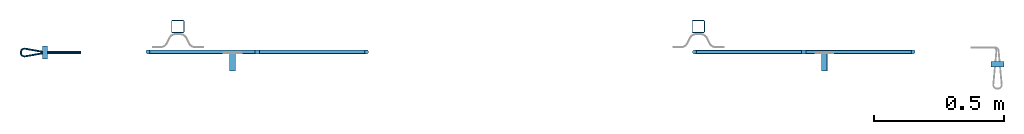
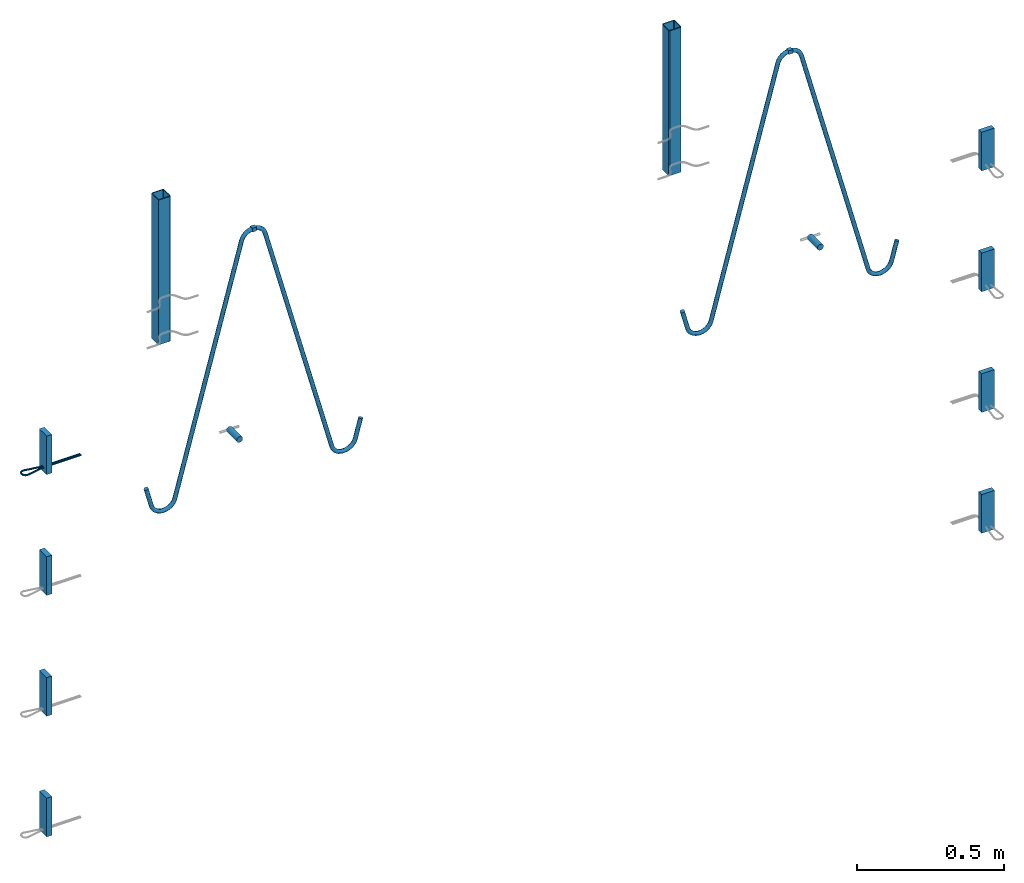
# One storey, part 1 of 5: 8 plates, 6 beams, 3 reinforcing bars, 14 elements without a shape of their own.
"""IFC2X3 building model written with IfcOpenShell, lengths in millimetres."""

from ifc_helpers import new_model, entity, si_unit, frame, origin_with_axes, origin_2d_with_axis, place, context, subcontext, project, spatial, polyline, rectangle, hollow_rectangle, circle, outline, extrude, source, transform, mapped, material, type_object, element, aggregate, save


model = new_model("IFC2X3")

# Units and contexts
model_context = context("Model", 3, precision=1e-05, world=origin_with_axes())
body_context = subcontext(model_context, "Body", "Model", "MODEL_VIEW")
ifc_project = project(units=[si_unit("LENGTHUNIT", "METRE", prefix="MILLI"), si_unit("AREAUNIT", "SQUARE_METRE"), si_unit("VOLUMEUNIT", "CUBIC_METRE"), si_unit("MASSUNIT", "GRAM", prefix="KILO"), si_unit("TIMEUNIT", "SECOND"), si_unit("PLANEANGLEUNIT", "RADIAN"), si_unit("SOLIDANGLEUNIT", "STERADIAN"), si_unit("THERMODYNAMICTEMPERATUREUNIT", "DEGREE_CELSIUS"), si_unit("LUMINOUSINTENSITYUNIT", "LUMEN")], contexts=[model_context])

# Site, building, storey
site_placement = place(None, origin_with_axes())
site = spatial("IfcSite", under=ifc_project, at=site_placement, CompositionType="ELEMENT")
building_placement = place(site_placement, origin_with_axes())
building = spatial("IfcBuilding", under=site, at=building_placement, Name="Undefined", CompositionType="ELEMENT")
storey_placement = place(building_placement, origin_with_axes())
storey = spatial("IfcBuildingStorey", under=building, at=storey_placement, Name="Undefined", CompositionType="ELEMENT", Elevation=0.0)

# Assembly, beam
assembly_1_placement = place(storey_placement, origin_with_axes())
assembly_1 = element("IfcElementAssembly", 1, at=assembly_1_placement, inside=storey, Name="Steel Assembly", AssemblyPlace="NOTDEFINED", PredefinedType="RIGID_FRAME")
ifc_material_1 = material(Name="STEEL/S235JR")
beam_type_1 = type_object("IfcBeamType", Name="16X16", PredefinedType="NOTDEFINED")
beam_1_placement = place(assembly_1_placement, frame((38933.0878652847, 7577.12506851134, 2796.99992149588), z_axis=(0.0, 0.0, 1.0), x_axis=(-0.999999999544916, 3.01690000135643e-05, 0.0)))
beam_1 = element("IfcBeam", 2, at=beam_1_placement, type_object=beam_type_1, material=ifc_material_1, Name="SA_16", ObjectType="16X16", context=body_context, shape_type="SweptSolid", body=[
    extrude(rectangle(XDim=16.0, YDim=16.0, at=origin_2d_with_axis()), frame((15.9999999995179, 0.0, -4.54747350886464e-13), z_axis=(-1.0, 0.0, 0.0), x_axis=(0.0, -1.0, 0.0)), (0.0, 0.0, 1.0), 16.0),
])

assembly_2_placement = place(storey_placement, origin_with_axes())
assembly_2 = element("IfcElementAssembly", 3, at=assembly_2_placement, inside=storey, Name="Steel Assembly", AssemblyPlace="NOTDEFINED", PredefinedType="RIGID_FRAME")
beam_2_placement = place(assembly_2_placement, frame((36817.0878663104, 7577.18890609153, 2796.99992149588), z_axis=(0.0, 0.0, 1.0), x_axis=(0.999999999544916, -3.01690000135232e-05, 0.0)))
beam_2 = element("IfcBeam", 4, at=beam_2_placement, type_object=beam_type_1, material=ifc_material_1, Name="SA_16", ObjectType="16X16", context=body_context, shape_type="SweptSolid", body=[
    extrude(rectangle(XDim=16.0, YDim=16.0, at=origin_2d_with_axis()), frame((15.9999999995179, 0.0, -4.54747350886464e-13), z_axis=(-1.0, 0.0, 0.0), x_axis=(0.0, -1.0, 0.0)), (0.0, 0.0, 1.0), 16.0),
])

assembly_3_placement = place(storey_placement, origin_with_axes())
assembly_3 = element("IfcElementAssembly", 5, at=assembly_3_placement, inside=storey, Name="Steel Assembly", AssemblyPlace="NOTDEFINED", PredefinedType="RIGID_FRAME")
ifc_material_2 = material(Name="STEEL/S235J0")
beam_type_2 = type_object("IfcBeamType", Name="P50X50X3", PredefinedType="NOTDEFINED")
beam_3_placement = place(assembly_3_placement, frame((38520.0052772973, 7674.92340090209, 2984.99992151562), z_axis=(0.999999999544916, -3.01690000135232e-05, 0.0), x_axis=(-8.33812647651968e-12, 3.06316909920404e-12, -1.0)))
beam_3 = element("IfcBeam", 6, at=beam_3_placement, type_object=beam_type_2, material=ifc_material_2, Name="603", ObjectType="P50X50X3", context=body_context, shape_type="SweptSolid", body=[
    extrude(hollow_rectangle(XDim=50.0, YDim=50.0, WallThickness=3.0, InnerFilletRadius=3.0, OuterFilletRadius=6.0, at=origin_2d_with_axis()), frame((600.0, 0.0, 0.0), z_axis=(-1.0, 0.0, 0.0), x_axis=(0.0, -1.0, 0.0)), (0.0, 0.0, 1.0), 600.0),
])
aggregate(assembly_3, [beam_3])

assembly_4_placement = place(storey_placement, origin_with_axes())
assembly_4 = element("IfcElementAssembly", 7, at=assembly_4_placement, inside=storey, Name="Steel Assembly", AssemblyPlace="NOTDEFINED", PredefinedType="RIGID_FRAME")
beam_4_placement = place(assembly_4_placement, frame((36520.0052791705, 7674.98373889061, 2984.99992151562), z_axis=(0.999999999544916, -3.01690000135232e-05, 0.0), x_axis=(-8.33812647651968e-12, 3.06316909920404e-12, -1.0)))
beam_4 = element("IfcBeam", 8, at=beam_4_placement, type_object=beam_type_2, material=ifc_material_2, Name="603", ObjectType="P50X50X3", context=body_context, shape_type="SweptSolid", body=[
    extrude(hollow_rectangle(XDim=50.0, YDim=50.0, WallThickness=3.0, InnerFilletRadius=3.0, OuterFilletRadius=6.0, at=origin_2d_with_axis()), frame((600.0, 0.0, 0.0), z_axis=(-1.0, 0.0, 0.0), x_axis=(0.0, -1.0, 0.0)), (0.0, 0.0, 1.0), 600.0),
])
aggregate(assembly_4, [beam_4])

assembly_5_placement = place(storey_placement, origin_with_axes())
assembly_5 = element("IfcElementAssembly", 9, at=assembly_5_placement, inside=storey, Name="Steel Assembly", AssemblyPlace="NOTDEFINED", PredefinedType="RIGID_FRAME")
ifc_material_3 = material()
beam_type_3 = type_object("IfcBeamType", Name="D24", PredefinedType="NOTDEFINED")
beam_5_placement = place(assembly_5_placement, frame((39004.4034584927, 7504.90878689104, 1999.99992149339), z_axis=(0.0, 0.0, 1.0), x_axis=(3.01689999884146e-05, 0.999999999544916, 0.0)))
beam_5 = element("IfcBeam", 10, at=beam_5_placement, type_object=beam_type_3, material=ifc_material_3, ObjectType="D24", context=body_context, shape_type="SweptSolid", body=[
    extrude(circle(Radius=12.0, at=origin_2d_with_axis()), frame((70.0000000002128, 0.0, 2.27373675443232e-13), z_axis=(-1.0, 0.0, 0.0), x_axis=(0.0, -1.0, 0.0)), (0.0, 0.0, 1.0), 70.0),
])
aggregate(assembly_5, [beam_5])

assembly_6_placement = place(storey_placement, origin_with_axes())
assembly_6 = element("IfcElementAssembly", 11, at=assembly_6_placement, inside=storey, Name="Steel Assembly", AssemblyPlace="NOTDEFINED", PredefinedType="RIGID_FRAME")
beam_6_placement = place(assembly_6_placement, frame((36730.0001505243, 7504.97740344245, 1999.99992151007), z_axis=(0.0, 0.0, 1.0), x_axis=(3.01689999884146e-05, 0.999999999544916, 0.0)))
beam_6 = element("IfcBeam", 12, at=beam_6_placement, type_object=beam_type_3, material=ifc_material_3, ObjectType="D24", context=body_context, shape_type="SweptSolid", body=[
    extrude(circle(Radius=12.0, at=origin_2d_with_axis()), frame((70.0000000002128, 0.0, 2.27373675443232e-13), z_axis=(-1.0, 0.0, 0.0), x_axis=(0.0, -1.0, 0.0)), (0.0, 0.0, 1.0), 70.0),
])
aggregate(assembly_6, [beam_6])

# Assembly, plate
assembly_7_placement = place(storey_placement, origin_with_axes())
assembly_7 = element("IfcElementAssembly", 13, at=assembly_7_placement, inside=storey, Name="Steel Assembly", AssemblyPlace="NOTDEFINED", PredefinedType="RIGID_FRAME")
ifc_material_4 = material(Name="STEEL/Steel_Undefined")
plate_type = type_object("IfcPlateType", Name="PL160X20", PredefinedType="NOTDEFINED")
plate_1_placement = place(assembly_7_placement, frame((39694.4018553906, 7519.89476329164, 2162.4999215154), z_axis=(-8.33812647651968e-12, 3.06316909920404e-12, -1.0), x_axis=(-0.999999999544916, 3.01690000135643e-05, 0.0)))
plate_1 = element("IfcPlate", 14, at=plate_1_placement, type_object=plate_type, material=ifc_material_4, Name="PVL80", ObjectType="PL160X20", context=body_context, shape_type="SweptSolid", body=[
    extrude(outline(polyline([(0.0, 0.0), (49.9999999994689, -5.50244294572622e-10), (49.9999999993233, 19.9999999995835), (4.8748916015029e-10, 20.0000000000382), (0.0, 0.0)])), frame((0.0, 0.0, -80.0), z_axis=(0.0, 0.0, 1.0), x_axis=(1.0, 0.0, 0.0)), (0.0, 0.0, 1.0), 160.0),
])
aggregate(assembly_7, [plate_1])

assembly_8_placement = place(storey_placement, origin_with_axes())
assembly_8 = element("IfcElementAssembly", 15, at=assembly_8_placement, inside=storey, Name="Steel Assembly", AssemblyPlace="NOTDEFINED", PredefinedType="RIGID_FRAME")
plate_2_placement = place(assembly_8_placement, frame((39694.4018553915, 7519.89476329164, 1662.4999215154), z_axis=(-8.33812647651968e-12, 3.06316909920404e-12, -1.0), x_axis=(-0.999999999544916, 3.01690000135643e-05, 0.0)))
plate_2 = element("IfcPlate", 16, at=plate_2_placement, type_object=plate_type, material=ifc_material_4, Name="PVL80", ObjectType="PL160X20", context=body_context, shape_type="SweptSolid", body=[
    extrude(outline(polyline([(0.0, 0.0), (49.9999999994689, -5.50244294572622e-10), (49.9999999993233, 19.9999999995835), (4.8748916015029e-10, 20.0000000000382), (0.0, 0.0)])), frame((0.0, 0.0, -80.0), z_axis=(0.0, 0.0, 1.0), x_axis=(1.0, 0.0, 0.0)), (0.0, 0.0, 1.0), 160.0),
])
aggregate(assembly_8, [plate_2])

assembly_9_placement = place(storey_placement, origin_with_axes())
assembly_9 = element("IfcElementAssembly", 17, at=assembly_9_placement, inside=storey, Name="Steel Assembly", AssemblyPlace="NOTDEFINED", PredefinedType="RIGID_FRAME")
plate_3_placement = place(assembly_9_placement, frame((39694.4018553924, 7519.89476329164, 1162.4999215154), z_axis=(-8.33812647651968e-12, 3.06316909920404e-12, -1.0), x_axis=(-0.999999999544916, 3.01690000135643e-05, 0.0)))
plate_3 = element("IfcPlate", 18, at=plate_3_placement, type_object=plate_type, material=ifc_material_4, Name="PVL80", ObjectType="PL160X20", context=body_context, shape_type="SweptSolid", body=[
    extrude(outline(polyline([(0.0, 0.0), (49.9999999994689, -5.50244294572622e-10), (49.9999999993233, 19.9999999995835), (4.8748916015029e-10, 20.0000000000382), (0.0, 0.0)])), frame((0.0, 0.0, -80.0), z_axis=(0.0, 0.0, 1.0), x_axis=(1.0, 0.0, 0.0)), (0.0, 0.0, 1.0), 160.0),
])
aggregate(assembly_9, [plate_3])

assembly_10_placement = place(storey_placement, origin_with_axes())
assembly_10 = element("IfcElementAssembly", 19, at=assembly_10_placement, inside=storey, Name="Steel Assembly", AssemblyPlace="NOTDEFINED", PredefinedType="RIGID_FRAME")
plate_4_placement = place(assembly_10_placement, frame((39694.4018553933, 7519.89476329164, 662.4999215154), z_axis=(-8.33812647651968e-12, 3.06316909920404e-12, -1.0), x_axis=(-0.999999999544916, 3.01690000135643e-05, 0.0)))
plate_4 = element("IfcPlate", 20, at=plate_4_placement, type_object=plate_type, material=ifc_material_4, Name="PVL80", ObjectType="PL160X20", context=body_context, shape_type="SweptSolid", body=[
    extrude(outline(polyline([(0.0, 0.0), (49.9999999994689, -5.50244294572622e-10), (49.9999999993233, 19.9999999995835), (4.8748916015029e-10, 20.0000000000382), (0.0, 0.0)])), frame((0.0, 0.0, -80.0), z_axis=(0.0, 0.0, 1.0), x_axis=(1.0, 0.0, 0.0)), (0.0, 0.0, 1.0), 160.0),
])
aggregate(assembly_10, [plate_4])

assembly_11_placement = place(storey_placement, origin_with_axes())
assembly_11 = element("IfcElementAssembly", 21, at=assembly_11_placement, inside=storey, Name="Steel Assembly", AssemblyPlace="NOTDEFINED", PredefinedType="RIGID_FRAME")
plate_5_placement = place(assembly_11_placement, frame((36000.0015084842, 7549.99942681677, 2162.49992151551), z_axis=(-8.33812647651968e-12, 3.06316909920404e-12, -1.0), x_axis=(3.01689999884146e-05, 0.999999999544916, 0.0)))
plate_5 = element("IfcPlate", 22, at=plate_5_placement, type_object=plate_type, material=ifc_material_4, Name="PVL80", ObjectType="PL160X20", context=body_context, shape_type="SweptSolid", body=[
    extrude(outline(polyline([(0.0, 0.0), (49.9999999994689, -5.50244294572622e-10), (49.9999999993233, 19.9999999995835), (4.8748916015029e-10, 20.0000000000382), (0.0, 0.0)])), frame((0.0, 0.0, -80.0), z_axis=(0.0, 0.0, 1.0), x_axis=(1.0, 0.0, 0.0)), (0.0, 0.0, 1.0), 160.0),
])

assembly_12_placement = place(storey_placement, origin_with_axes())
assembly_12 = element("IfcElementAssembly", 23, at=assembly_12_placement, inside=storey, Name="Steel Assembly", AssemblyPlace="NOTDEFINED", PredefinedType="RIGID_FRAME")
plate_6_placement = place(assembly_12_placement, frame((36000.0015084851, 7549.99942681677, 1662.49992151551), z_axis=(-8.33812647651968e-12, 3.06316909920404e-12, -1.0), x_axis=(3.01689999884146e-05, 0.999999999544916, 0.0)))
plate_6 = element("IfcPlate", 24, at=plate_6_placement, type_object=plate_type, material=ifc_material_4, Name="PVL80", ObjectType="PL160X20", context=body_context, shape_type="SweptSolid", body=[
    extrude(outline(polyline([(0.0, 0.0), (49.9999999994689, -5.50244294572622e-10), (49.9999999993233, 19.9999999995835), (4.8748916015029e-10, 20.0000000000382), (0.0, 0.0)])), frame((0.0, 0.0, -80.0), z_axis=(0.0, 0.0, 1.0), x_axis=(1.0, 0.0, 0.0)), (0.0, 0.0, 1.0), 160.0),
])
aggregate(assembly_12, [plate_6])

assembly_13_placement = place(storey_placement, origin_with_axes())
assembly_13 = element("IfcElementAssembly", 25, at=assembly_13_placement, inside=storey, Name="Steel Assembly", AssemblyPlace="NOTDEFINED", PredefinedType="RIGID_FRAME")
plate_7_placement = place(assembly_13_placement, frame((36000.001508486, 7549.99942681677, 1162.49992151551), z_axis=(-8.33812647651968e-12, 3.06316909920404e-12, -1.0), x_axis=(3.01689999884146e-05, 0.999999999544916, 0.0)))
plate_7 = element("IfcPlate", 26, at=plate_7_placement, type_object=plate_type, material=ifc_material_4, Name="PVL80", ObjectType="PL160X20", context=body_context, shape_type="SweptSolid", body=[
    extrude(outline(polyline([(0.0, 0.0), (49.9999999994689, -5.50244294572622e-10), (49.9999999993233, 19.9999999995835), (4.8748916015029e-10, 20.0000000000382), (0.0, 0.0)])), frame((0.0, 0.0, -80.0), z_axis=(0.0, 0.0, 1.0), x_axis=(1.0, 0.0, 0.0)), (0.0, 0.0, 1.0), 160.0),
])
aggregate(assembly_13, [plate_7])

assembly_14_placement = place(storey_placement, origin_with_axes())
assembly_14 = element("IfcElementAssembly", 27, at=assembly_14_placement, inside=storey, Name="Steel Assembly", AssemblyPlace="NOTDEFINED", PredefinedType="RIGID_FRAME")
plate_8_placement = place(assembly_14_placement, frame((36000.001508487, 7549.99942681677, 662.499921515511), z_axis=(-8.33812647651968e-12, 3.06316909920404e-12, -1.0), x_axis=(3.01689999884146e-05, 0.999999999544916, 0.0)))
plate_8 = element("IfcPlate", 28, at=plate_8_placement, type_object=plate_type, material=ifc_material_4, Name="PVL80", ObjectType="PL160X20", context=body_context, shape_type="SweptSolid", body=[
    extrude(outline(polyline([(0.0, 0.0), (49.9999999994689, -5.50244294572622e-10), (49.9999999993233, 19.9999999995835), (4.8748916015029e-10, 20.0000000000382), (0.0, 0.0)])), frame((0.0, 0.0, -80.0), z_axis=(0.0, 0.0, 1.0), x_axis=(1.0, 0.0, 0.0)), (0.0, 0.0, 1.0), 160.0),
])
aggregate(assembly_14, [plate_8])

# Reinforcing bar
ifc_material_5 = material(Name="S235JR")
ifc_direction_1 = entity("IfcDirection", [-0.86602540378624, 2.77797737119958e-12, -0.499999999996879])
ifc_direction_2 = entity("IfcDirection", [0.0, -1.0, 0.0])
ifc_direction_3 = entity("IfcDirection", [-0.499999999996879, -1.93317702492497e-12, 0.86602540378624])
vector_1 = entity("IfcVector", entity("IfcDirection", [1.0, 0.0, 0.0]), 1.0)
ifc_direction_4 = entity("IfcDirection", [0.0, 1.0, 0.0])
shared_shape_1 = source(origin_with_axes(), body_context, "Body", "AdvancedSweptSolid", [
    entity("IfcSweptDiskSolid", entity("IfcCompositeCurve", [entity("IfcCompositeCurveSegment", "CONTINUOUS", True, entity("IfcTrimmedCurve", entity("IfcLine", entity("IfcCartesianPoint", [0.0, 0.0, 0.0]), entity("IfcVector", ifc_direction_1, 1.0)), [entity("IfcParameterValue", 0.0)], [entity("IfcParameterValue", 81.1547005386031)], True, "PARAMETER")), entity("IfcCompositeCurveSegment", "CONTINUOUS", True, entity("IfcTrimmedCurve", entity("IfcCircle", entity("IfcAxis2Placement3D", entity("IfcCartesianPoint", [-47.2820323032387, 3.14372064809266e-10, -80.4145188432153]), ifc_direction_2, ifc_direction_3), 46.0), [entity("IfcParameterValue", 0.0)], [entity("IfcParameterValue", 1.04719755119186)], True, "PARAMETER")), entity("IfcCompositeCurveSegment", "CONTINUOUS", True, entity("IfcTrimmedCurve", entity("IfcLine", entity("IfcCartesianPoint", [-93.2820323032387, 3.80575746066794e-10, -80.4145188428318]), entity("IfcVector", entity("IfcDirection", [-8.33812647651968e-12, 3.06316909920404e-12, -1.0]), 1.0)), [entity("IfcParameterValue", 0.0)], [entity("IfcParameterValue", 3.15470053757427)], True, "PARAMETER")), entity("IfcCompositeCurveSegment", "CONTINUOUS", True, entity("IfcTrimmedCurve", entity("IfcCircle", entity("IfcAxis2Placement3D", entity("IfcCartesianPoint", [-47.282032303265, 4.18798965433473e-10, -83.5692193807896]), ifc_direction_2, entity("IfcDirection", [-1.0, 0.0, 0.0])), 46.0), [entity("IfcParameterValue", 0.0)], [entity("IfcParameterValue", 1.57079632680391)], True, "PARAMETER")), entity("IfcCompositeCurveSegment", "CONTINUOUS", True, entity("IfcTrimmedCurve", entity("IfcLine", entity("IfcCartesianPoint", [-47.2820323032338, 5.59704743997116e-10, -129.56921938079]), vector_1), [entity("IfcParameterValue", 0.0)], [entity("IfcParameterValue", 1010.03909475648)], True, "PARAMETER")), entity("IfcCompositeCurveSegment", "CONTINUOUS", True, entity("IfcTrimmedCurve", entity("IfcCircle", entity("IfcAxis2Placement3D", entity("IfcCartesianPoint", [962.757062453275, 1.1903227576388e-09, -175.569219380103]), ifc_direction_4, entity("IfcDirection", [0.0, 0.0, 1.0])), 46.0), [entity("IfcParameterValue", 0.0)], [entity("IfcParameterValue", 1.30899693900706)], True, "PARAMETER")), entity("IfcCompositeCurveSegment", "CONTINUOUS", True, entity("IfcTrimmedCurve", entity("IfcLine", entity("IfcCartesianPoint", [1007.1896504627, 1.21699865000378e-09, -163.663543305859]), entity("IfcVector", entity("IfcDirection", [0.258819045092255, 2.34585988173848e-13, -0.965925826291819]), 1.0)), [entity("IfcParameterValue", 0.0)], [entity("IfcParameterValue", 3.06930795080784)], True, "PARAMETER")), entity("IfcCompositeCurveSegment", "CONTINUOUS", True, entity("IfcTrimmedCurve", entity("IfcCircle", entity("IfcAxis2Placement3D", entity("IfcCartesianPoint", [963.551457806197, 1.39401710534484e-09, -178.533943198631]), ifc_direction_4, entity("IfcDirection", [0.965925826291821, -3.83257475440008e-12, 0.258819045092248])), 46.0), [entity("IfcParameterValue", 0.0)], [entity("IfcParameterValue", 1.30899693899649)], True, "PARAMETER")), entity("IfcCompositeCurveSegment", "CONTINUOUS", True, entity("IfcTrimmedCurve", entity("IfcLine", entity("IfcCartesianPoint", [986.551457805744, 1.35881097435223e-09, -218.371111772977]), entity("IfcVector", ifc_direction_1, 1.0)), [entity("IfcParameterValue", 0.0)], [entity("IfcParameterValue", 1010.03909476038)], True, "PARAMETER")), entity("IfcCompositeCurveSegment", "CONTINUOUS", True, entity("IfcTrimmedCurve", entity("IfcCircle", entity("IfcAxis2Placement3D", entity("IfcCartesianPoint", [134.83194292162, 5.25929879082697e-09, -763.227827717565]), ifc_direction_2, ifc_direction_3), 46.0), [entity("IfcParameterValue", 0.0)], [entity("IfcParameterValue", 1.57079632679425)], True, "PARAMETER")), entity("IfcCompositeCurveSegment", "CONTINUOUS", True, entity("IfcTrimmedCurve", entity("IfcLine", entity("IfcCartesianPoint", [94.9947743472596, 5.43238291069089e-09, -786.227827717086]), entity("IfcVector", entity("IfcDirection", [0.499999999989597, 2.17424943904939e-12, -0.866025403790445]), 1.0)), [entity("IfcParameterValue", 0.0)], [entity("IfcParameterValue", 3.15470053750037)], True, "PARAMETER")), entity("IfcCompositeCurveSegment", "CONTINUOUS", True, entity("IfcTrimmedCurve", entity("IfcCircle", entity("IfcAxis2Placement3D", entity("IfcCartesianPoint", [136.409293190338, 5.36310965899477e-09, -765.959878524392]), ifc_direction_2, ifc_direction_1), 46.0), [entity("IfcParameterValue", 0.0)], [entity("IfcParameterValue", 1.04719755120132)], True, "PARAMETER")), entity("IfcCompositeCurveSegment", "DISCONTINUOUS", True, entity("IfcTrimmedCurve", entity("IfcLine", entity("IfcCartesianPoint", [136.409293190002, 5.48779177920529e-09, -811.959878524392]), vector_1), [entity("IfcParameterValue", 0.0)], [entity("IfcParameterValue", 81.154700538021)], True, "PARAMETER"))], False), 8.0, None, 0.0, 2199.62028125336),
])
reinforcing_bar_1_placement = place(assembly_1_placement, frame((38605.7975933633, 7577.1349425226, 1742.85016237043), z_axis=(-0.965925825826314, 2.91409999945244e-05, 0.25881904518902), x_axis=(0.258819045071245, -7.80800000212321e-06, 0.965925826265891)))
reinforcing_bar_1 = element("IfcReinforcingBar", 29, at=reinforcing_bar_1_placement, material=ifc_material_5, Name="SA_16", BarRole="NOTDEFINED", CrossSectionArea=0.0, NominalDiameter=16.0, context=body_context, shape_type="MappedRepresentation", body=[
    mapped(shared_shape_1, transform((93.2820323036485, -5.32054400537163e-10, 129.569219380821))),
])

aggregate(assembly_1, [beam_1, reinforcing_bar_1])

ifc_direction_5 = entity("IfcDirection", [-0.86602540378624, 2.77797737119958e-12, -0.499999999996879])
ifc_direction_6 = entity("IfcDirection", [0.0, -1.0, 0.0])
ifc_direction_7 = entity("IfcDirection", [-0.499999999996879, -1.93317702492497e-12, 0.86602540378624])
vector_2 = entity("IfcVector", entity("IfcDirection", [1.0, 0.0, 0.0]), 1.0)
ifc_direction_8 = entity("IfcDirection", [0.0, 1.0, 0.0])
shared_shape_2 = source(origin_with_axes(), body_context, "Body", "AdvancedSweptSolid", [
    entity("IfcSweptDiskSolid", entity("IfcCompositeCurve", [entity("IfcCompositeCurveSegment", "CONTINUOUS", True, entity("IfcTrimmedCurve", entity("IfcLine", entity("IfcCartesianPoint", [0.0, 0.0, 0.0]), entity("IfcVector", ifc_direction_5, 1.0)), [entity("IfcParameterValue", 0.0)], [entity("IfcParameterValue", 81.154700538248)], True, "PARAMETER")), entity("IfcCompositeCurveSegment", "CONTINUOUS", True, entity("IfcTrimmedCurve", entity("IfcCircle", entity("IfcAxis2Placement3D", entity("IfcCartesianPoint", [-47.2820323032387, 3.14372064809266e-10, -80.4145188432153]), ifc_direction_6, ifc_direction_7), 46.0), [entity("IfcParameterValue", 0.0)], [entity("IfcParameterValue", 1.04719755119786)], True, "PARAMETER")), entity("IfcCompositeCurveSegment", "CONTINUOUS", True, entity("IfcTrimmedCurve", entity("IfcLine", entity("IfcCartesianPoint", [-93.2820323032387, 3.80575746066794e-10, -80.4145188428318]), entity("IfcVector", entity("IfcDirection", [-8.33812647651968e-12, 3.06316909920404e-12, -1.0]), 1.0)), [entity("IfcParameterValue", 0.0)], [entity("IfcParameterValue", 3.15470053771323)], True, "PARAMETER")), entity("IfcCompositeCurveSegment", "CONTINUOUS", True, entity("IfcTrimmedCurve", entity("IfcCircle", entity("IfcAxis2Placement3D", entity("IfcCartesianPoint", [-47.282032303265, 4.18798965433473e-10, -83.5692193807896]), ifc_direction_6, entity("IfcDirection", [-1.0, 0.0, 0.0])), 46.0), [entity("IfcParameterValue", 0.0)], [entity("IfcParameterValue", 1.5707963267969)], True, "PARAMETER")), entity("IfcCompositeCurveSegment", "CONTINUOUS", True, entity("IfcTrimmedCurve", entity("IfcLine", entity("IfcCartesianPoint", [-47.2820323032338, 5.59704743997116e-10, -129.56921938079]), vector_2), [entity("IfcParameterValue", 0.0)], [entity("IfcParameterValue", 1010.03909475912)], True, "PARAMETER")), entity("IfcCompositeCurveSegment", "CONTINUOUS", True, entity("IfcTrimmedCurve", entity("IfcCircle", entity("IfcAxis2Placement3D", entity("IfcCartesianPoint", [962.757062453275, 1.1903227576388e-09, -175.569219380103]), ifc_direction_8, entity("IfcDirection", [0.0, 0.0, 1.0])), 46.0), [entity("IfcParameterValue", 0.0)], [entity("IfcParameterValue", 1.308996939)], True, "PARAMETER")), entity("IfcCompositeCurveSegment", "CONTINUOUS", True, entity("IfcTrimmedCurve", entity("IfcLine", entity("IfcCartesianPoint", [1007.1896504627, 1.21699865000378e-09, -163.663543305859]), entity("IfcVector", entity("IfcDirection", [0.258819045092255, 2.34585988173848e-13, -0.965925826291819]), 1.0)), [entity("IfcParameterValue", 0.0)], [entity("IfcParameterValue", 3.06930795098158)], True, "PARAMETER")), entity("IfcCompositeCurveSegment", "CONTINUOUS", True, entity("IfcTrimmedCurve", entity("IfcCircle", entity("IfcAxis2Placement3D", entity("IfcCartesianPoint", [963.551457806197, 1.39401710534484e-09, -178.533943198631]), ifc_direction_8, entity("IfcDirection", [0.965925826291821, -3.83257475440008e-12, 0.258819045092248])), 46.0), [entity("IfcParameterValue", 0.0)], [entity("IfcParameterValue", 1.30899693900259)], True, "PARAMETER")), entity("IfcCompositeCurveSegment", "CONTINUOUS", True, entity("IfcTrimmedCurve", entity("IfcLine", entity("IfcCartesianPoint", [986.551457805744, 1.35881097435223e-09, -218.371111772977]), entity("IfcVector", ifc_direction_5, 1.0)), [entity("IfcParameterValue", 0.0)], [entity("IfcParameterValue", 1010.03909475814)], True, "PARAMETER")), entity("IfcCompositeCurveSegment", "CONTINUOUS", True, entity("IfcTrimmedCurve", entity("IfcCircle", entity("IfcAxis2Placement3D", entity("IfcCartesianPoint", [134.83194292162, 5.25929879082697e-09, -763.227827717565]), ifc_direction_6, ifc_direction_7), 46.0), [entity("IfcParameterValue", 0.0)], [entity("IfcParameterValue", 1.57079632679936)], True, "PARAMETER")), entity("IfcCompositeCurveSegment", "CONTINUOUS", True, entity("IfcTrimmedCurve", entity("IfcLine", entity("IfcCartesianPoint", [94.9947743472596, 5.43238291069089e-09, -786.227827717086]), entity("IfcVector", entity("IfcDirection", [0.499999999989597, 2.17424943904939e-12, -0.866025403790445]), 1.0)), [entity("IfcParameterValue", 0.0)], [entity("IfcParameterValue", 3.1547005377164)], True, "PARAMETER")), entity("IfcCompositeCurveSegment", "CONTINUOUS", True, entity("IfcTrimmedCurve", entity("IfcCircle", entity("IfcAxis2Placement3D", entity("IfcCartesianPoint", [136.409293190338, 5.36310965899477e-09, -765.959878524392]), ifc_direction_6, ifc_direction_5), 46.0), [entity("IfcParameterValue", 0.0)], [entity("IfcParameterValue", 1.04719755119522)], True, "PARAMETER")), entity("IfcCompositeCurveSegment", "DISCONTINUOUS", True, entity("IfcTrimmedCurve", entity("IfcLine", entity("IfcCartesianPoint", [136.409293190002, 5.48779177920529e-09, -811.959878524392]), vector_2), [entity("IfcParameterValue", 0.0)], [entity("IfcParameterValue", 81.15470053841)], True, "PARAMETER"))], False), 8.0, None, 0.0, 2199.62028125432),
])
reinforcing_bar_2_placement = place(assembly_2_placement, frame((37144.3781382318, 7577.17903208027, 1742.85016237043), z_axis=(0.965925825826314, -2.91409999945244e-05, 0.25881904518902), x_axis=(-0.258819045071245, 7.80800000212321e-06, 0.965925826265891)))
reinforcing_bar_2 = element("IfcReinforcingBar", 30, at=reinforcing_bar_2_placement, material=ifc_material_5, Name="SA_16", BarRole="NOTDEFINED", CrossSectionArea=0.0, NominalDiameter=16.0, context=body_context, shape_type="MappedRepresentation", body=[
    mapped(shared_shape_2, transform((93.2820323036485, -5.32054400537163e-10, 129.569219380821))),
])

aggregate(assembly_2, [beam_2, reinforcing_bar_2])

ifc_material_6 = material(Name="Undefined")
ifc_direction_9 = entity("IfcDirection", [-1.0, 0.0, 0.0])
ifc_direction_10 = entity("IfcDirection", [0.0, -1.0, 0.0])
ifc_direction_11 = entity("IfcDirection", [0.0, 0.0, 1.0])
ifc_direction_12 = entity("IfcDirection", [0.0, 1.0, 0.0])
shared_shape_3 = source(origin_with_axes(), body_context, "Body", "AdvancedSweptSolid", [
    entity("IfcSweptDiskSolid", entity("IfcCompositeCurve", [entity("IfcCompositeCurveSegment", "CONTINUOUS", True, entity("IfcTrimmedCurve", entity("IfcLine", entity("IfcCartesianPoint", [0.0, 0.0, 0.0]), entity("IfcVector", ifc_direction_9, 1.0)), [entity("IfcParameterValue", 0.0)], [entity("IfcParameterValue", 145.82964572468)], True, "PARAMETER")), entity("IfcCompositeCurveSegment", "CONTINUOUS", True, entity("IfcTrimmedCurve", entity("IfcCircle", entity("IfcAxis2Placement3D", entity("IfcCartesianPoint", [-145.829645724701, -2.65262580298717e-10, -13.4999999997726]), ifc_direction_10, ifc_direction_11), 13.5), [entity("IfcParameterValue", 0.0)], [entity("IfcParameterValue", 0.172953396990131)], True, "PARAMETER")), entity("IfcCompositeCurveSegment", "CONTINUOUS", True, entity("IfcTrimmedCurve", entity("IfcLine", entity("IfcCartesianPoint", [-148.152893530611, -2.69488543439534e-10, -0.201409110797414]), entity("IfcVector", entity("IfcDirection", [-0.985080806590756, -1.79185154884274e-12, -0.172092430067405]), 1.0)), [entity("IfcParameterValue", 0.0)], [entity("IfcParameterValue", 67.0237996918215)], True, "PARAMETER")), entity("IfcCompositeCurveSegment", "CONTINUOUS", True, entity("IfcTrimmedCurve", entity("IfcCircle", entity("IfcAxis2Placement3D", entity("IfcCartesianPoint", [-216.499999997718, -3.93811205867437e-10, 1.56289321686128]), ifc_direction_12, entity("IfcDirection", [0.172092430067405, 3.13034306725014e-13, -0.985080806590757])), 13.5), [entity("IfcParameterValue", 0.0)], [entity("IfcParameterValue", 1.74374972378285)], True, "PARAMETER")), entity("IfcCompositeCurveSegment", "CONTINUOUS", True, entity("IfcTrimmedCurve", entity("IfcLine", entity("IfcCartesianPoint", [-229.999999997718, -4.18367562815547e-10, 1.56289321685286]), entity("IfcVector", ifc_direction_11, 1.0)), [entity("IfcParameterValue", 0.0)], [entity("IfcParameterValue", 2.87421356694823)], True, "PARAMETER")), entity("IfcCompositeCurveSegment", "CONTINUOUS", True, entity("IfcTrimmedCurve", entity("IfcCircle", entity("IfcAxis2Placement3D", entity("IfcCartesianPoint", [-216.49999999772, -3.93811205867436e-10, 4.43710678380951]), ifc_direction_12, ifc_direction_9), 13.5), [entity("IfcParameterValue", 0.0)], [entity("IfcParameterValue", 1.74374972378708)], True, "PARAMETER")), entity("IfcCompositeCurveSegment", "CONTINUOUS", True, entity("IfcTrimmedCurve", entity("IfcLine", entity("IfcCartesianPoint", [-214.17675219177, -3.89585242726546e-10, 17.7356976727778]), entity("IfcVector", entity("IfcDirection", [0.985080806590242, 1.79185154884149e-12, -0.17209243007035]), 1.0)), [entity("IfcParameterValue", 0.0)], [entity("IfcParameterValue", 67.023799691812)], True, "PARAMETER")), entity("IfcCompositeCurveSegment", "CONTINUOUS", True, entity("IfcTrimmedCurve", entity("IfcCircle", entity("IfcAxis2Placement3D", entity("IfcCartesianPoint", [-145.829645724667, -2.65262580298632e-10, 19.5000000002337]), ifc_direction_10, entity("IfcDirection", [-0.172092430070349, -3.13034306733245e-13, -0.985080806590242])), 13.5), [entity("IfcParameterValue", 0.0)], [entity("IfcParameterValue", 0.172953396990003)], True, "PARAMETER")), entity("IfcCompositeCurveSegment", "DISCONTINUOUS", True, entity("IfcTrimmedCurve", entity("IfcLine", entity("IfcCartesianPoint", [-145.829645724688, -2.65262580298694e-10, 6.00000000023373]), entity("IfcVector", entity("IfcDirection", [1.0, 0.0, 0.0]), 1.0)), [entity("IfcParameterValue", 0.0)], [entity("IfcParameterValue", 145.829645724696)], True, "PARAMETER"))], False), 3.5, None, 0.0, 432.414510641508),
])
reinforcing_bar_3_placement = place(assembly_11_placement, frame((36000.0023532172, 7577.99942680406, 2099.99992151551), z_axis=(3.01689999884146e-05, 0.999999999544916, 0.0), x_axis=(0.999999999544916, -3.01690000135232e-05, 0.0)))
reinforcing_bar_3 = element("IfcReinforcingBar", 31, at=reinforcing_bar_3_placement, material=ifc_material_6, Name="PVL80", BarRole="NOTDEFINED", CrossSectionArea=0.0, NominalDiameter=7.0, context=body_context, shape_type="MappedRepresentation", body=[
    mapped(shared_shape_3, transform((146.999999998538, 2.67391442321241e-10, -6.00000000023556))),
])

aggregate(assembly_11, [plate_5, reinforcing_bar_3])

save(model, "model.ifc")
